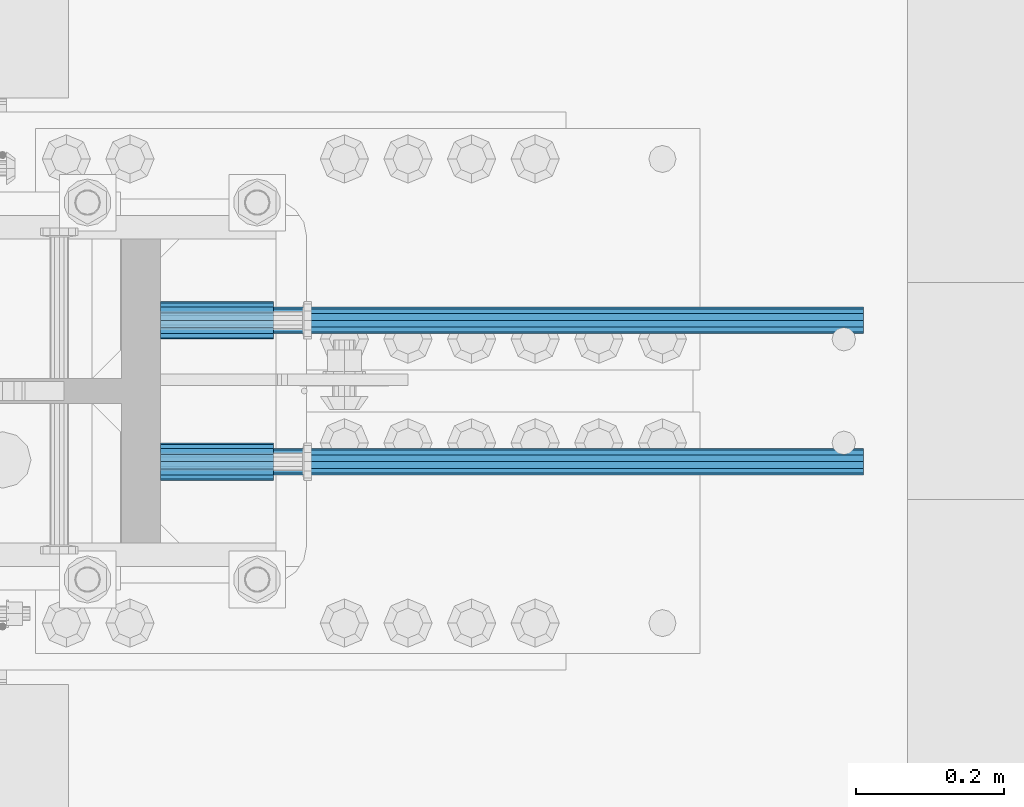
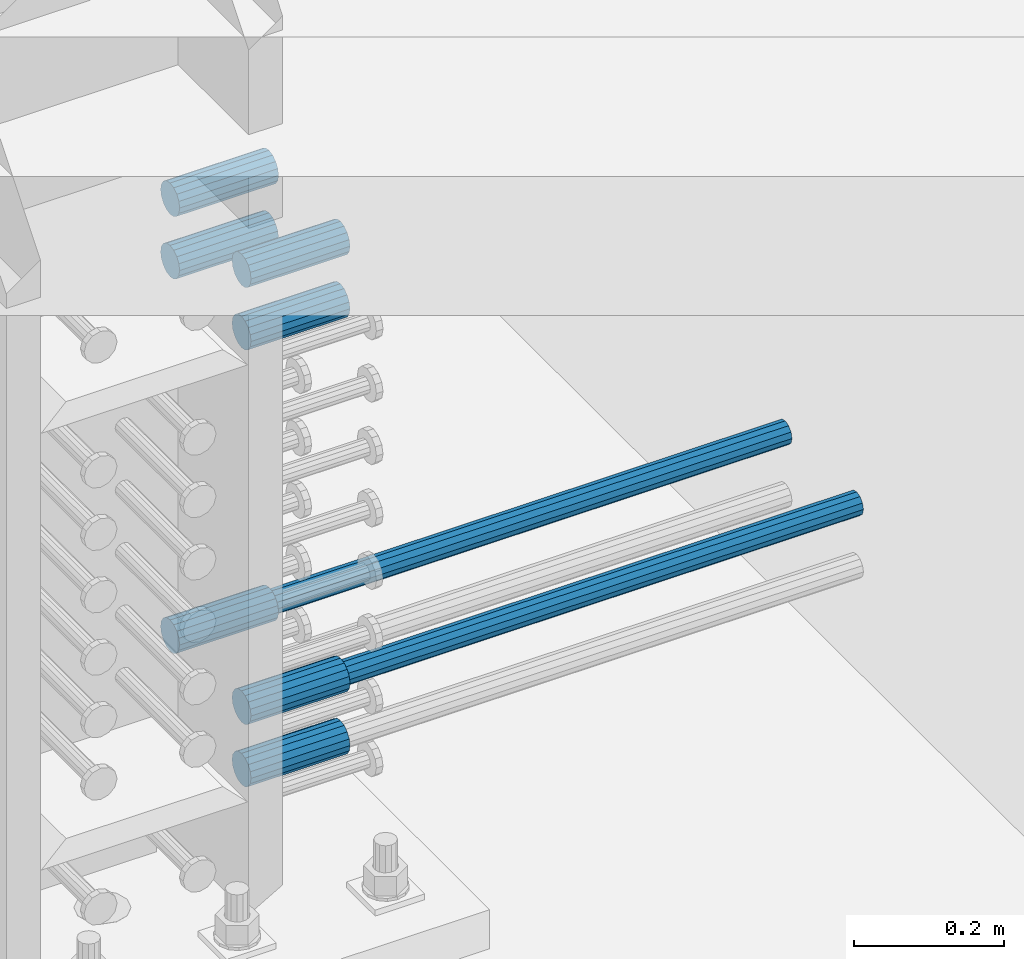
# One storey, part 1232 of 1763: 9 beams, 3 elements without a shape of their own.
"""IFC2X3 building model written with IfcOpenShell, lengths in millimetres."""

import ifcopenshell
import ifcopenshell.guid

model = None  # the IFC model being written
_history = None  # IfcOwnerHistory: only IFC2X3 demands one
_inside = {}  # id of a spatial element -> (the spatial element, [elements in it])
_under = {}  # id of a project, library or spatial element -> (it, [spatial elements below it])
_declared = {}  # id of a project -> (the project, [libraries it declares])
_typed = {}  # id of a type object -> (the type object, [elements of that type])
_made_of = {}  # id of a material, layer set ... -> (it, [elements and type objects made of it])


def new_model(schema):
    """Start an empty IFC model of exactly this schema.

    Asked for "IFC4X3", IfcOpenShell would pick the latest addendum, in which some entities
    have other attributes; the version numbers below select the first issue.
    IFC2X3 requires an IfcOwnerHistory on every rooted entity: one is made here for all.
    """
    global model, _history
    if schema == "IFC4X3":
        model = ifcopenshell.file(schema_version=(4, 3, 0, 0))
    else:
        model = ifcopenshell.file(schema=schema)
    _inside.clear()
    _under.clear()
    _declared.clear()
    _typed.clear()
    _made_of.clear()
    _history = None
    if model.schema == "IFC2X3":
        org = make("IfcOrganization", Name="unknown")
        user = make(
            "IfcPersonAndOrganization",
            ThePerson=make("IfcPerson", FamilyName="unknown"),
            TheOrganization=org,
        )
        app = make(
            "IfcApplication",
            ApplicationDeveloper=org,
            Version="unknown",
            ApplicationFullName="unknown",
            ApplicationIdentifier="unknown",
        )
        _history = make(
            "IfcOwnerHistory",
            OwningUser=user,
            OwningApplication=app,
            ChangeAction="ADDED",
            CreationDate=0,
        )
    return model


def make(cls, **values):
    """One entity of the class cls with the attributes given. An attribute that is None is left unset."""
    return model.create_entity(
        cls, **{name: value for name, value in values.items() if value is not None}
    )


def rooted(cls, **values):
    """An entity with a GlobalId (a new one), such as an element, a storey or a relation."""
    return make(cls, GlobalId=ifcopenshell.guid.new(), OwnerHistory=_history, **values)


def si_unit(unit_type, name, prefix=None):
    """IfcSIUnit, for example si_unit("LENGTHUNIT", "METRE", prefix="MILLI")."""
    return make("IfcSIUnit", UnitType=unit_type, Prefix=prefix, Name=name)


def assignment(units):
    """IfcUnitAssignment: the units of a project."""
    return None if units is None else make("IfcUnitAssignment", Units=units)


def point(xyz):
    """IfcCartesianPoint."""
    return None if xyz is None else make("IfcCartesianPoint", Coordinates=xyz)


def direction(xyz):
    """IfcDirection."""
    return None if xyz is None else make("IfcDirection", DirectionRatios=xyz)


def frame(location, z_axis=None, x_axis=None):
    """IfcAxis2Placement3D, a coordinate frame: its origin and axes. An axis left out is left unset."""
    return make(
        "IfcAxis2Placement3D",
        Location=point(location),
        Axis=direction(z_axis),
        RefDirection=direction(x_axis),
    )


def origin_with_axes():
    """The frame at (0, 0, 0) with the z axis (0, 0, 1) and the x axis (1, 0, 0) written out."""
    return frame((0.0, 0.0, 0.0), z_axis=(0.0, 0.0, 1.0), x_axis=(1.0, 0.0, 0.0))


def place(relative_to, where):
    """IfcLocalPlacement: puts the frame where relative to a parent placement (None: the world)."""
    return make(
        "IfcLocalPlacement", PlacementRelTo=relative_to, RelativePlacement=where
    )


def context(
    kind, dimensions, precision=None, world=None, true_north=None, identifier=None
):
    """IfcGeometricRepresentationContext, for example the 3D "Model" context."""
    return make(
        "IfcGeometricRepresentationContext",
        ContextIdentifier=identifier,
        ContextType=kind,
        CoordinateSpaceDimension=dimensions,
        Precision=precision,
        WorldCoordinateSystem=world,
        TrueNorth=true_north,
    )


def subcontext(parent, identifier, kind, view, scale=None):
    """IfcGeometricRepresentationSubContext, for example "Body" below "Model"."""
    return make(
        "IfcGeometricRepresentationSubContext",
        ContextIdentifier=identifier,
        ContextType=kind,
        ParentContext=parent,
        TargetScale=scale,
        TargetView=view,
    )


def project(units=None, contexts=None):
    """IfcProject with its units and contexts."""
    return rooted(
        "IfcProject",
        Name="project",
        RepresentationContexts=contexts,
        UnitsInContext=assignment(units),
    )


def spatial(cls, under=None, at=None, **own):
    """A site, building, storey or space (cls), placed at a placement, below another one or the project."""
    s = rooted(cls, ObjectPlacement=at, **own)
    if under is not None:
        _under.setdefault(under.id(), (under, []))[1].append(s)
    return s


def faces_of(points, faces, orient=None, outer=None):
    """IfcFace entities. A face is a list of loops; a loop is a list of indices into points, from 0.

    orient and outer hold one flag for each loop. By default every Orientation is true, the
    first loop of a face is its IfcFaceOuterBound and the others are IfcFaceBound.
    """
    made = []
    for i, loops in enumerate(faces):
        bounds = []
        for j, loop in enumerate(loops):
            is_outer = j == 0 if outer is None else outer[i][j]
            bounds.append(
                make(
                    "IfcFaceOuterBound" if is_outer else "IfcFaceBound",
                    Bound=make("IfcPolyLoop", Polygon=[points[k] for k in loop]),
                    Orientation=True if orient is None else orient[i][j],
                )
            )
        made.append(make("IfcFace", Bounds=bounds))
    return made


def faceted_brep(points, faces, orient=None, outer=None, voids=None):
    """IfcFacetedBrep: a solid bounded by flat faces; with voids (closed shells), ...WithVoids."""
    shared = [point(p) for p in points]
    hull = make("IfcClosedShell", CfsFaces=faces_of(shared, faces, orient, outer))
    if voids is None:
        return make("IfcFacetedBrep", Outer=hull)
    return make(
        "IfcFacetedBrepWithVoids",
        Outer=hull,
        Voids=[
            make(cls, CfsFaces=faces_of(shared, fs, o, b)) for cls, fs, o, b in voids
        ],
    )


def shape(context_of_items, identifier, shape_type, items):
    """IfcShapeRepresentation: the items that make up one representation, for example the "Body"."""
    return make(
        "IfcShapeRepresentation",
        ContextOfItems=context_of_items,
        RepresentationIdentifier=identifier,
        RepresentationType=shape_type,
        Items=items,
    )


def material(Name=None, Category=None):
    """IfcMaterial."""
    return make("IfcMaterial", Name=Name, Category=Category)


def made_of(thing, what):
    """Note that an element or type object is made of a material, layer set ...; save() writes the relation."""
    if what is not None:
        _made_of.setdefault(what.id(), (what, []))[1].append(thing)
    return thing


def type_object(cls, material=None, **own):
    """A type object (cls), such as IfcWallType, which elements share."""
    return made_of(rooted(cls, **own), material)


def element(
    cls,
    number,
    at=None,
    inside=None,
    cuts=None,
    type_object=None,
    material=None,
    context=None,
    identifier="Body",
    shape_type=None,
    held_by="IfcProductDefinitionShape",
    body=None,
    shapes=None,
    **own,
):
    """One element of the class cls, such as IfcWall. Its Tag is "e" and its number.

    at: its placement. inside: the storey or other place that contains it. cuts: it is an
    opening in that element (IfcRelVoidsElement). A single representation is given by context,
    identifier, shape_type and body (its items); several are given by shapes. held_by: the class
    of the entity that holds the representations. save() writes the other relations.
    """
    e = rooted(cls, Tag="e%d" % number, ObjectPlacement=at, **own)
    if body is not None:
        shapes = [shape(context, identifier, shape_type, body)]
    if shapes is not None:
        e.Representation = make(held_by, Representations=shapes)
    if inside is not None:
        _inside.setdefault(inside.id(), (inside, []))[1].append(e)
    if cuts is not None:
        rooted(
            "IfcRelVoidsElement", RelatingBuildingElement=cuts, RelatedOpeningElement=e
        )
    if type_object is not None:
        _typed.setdefault(type_object.id(), (type_object, []))[1].append(e)
    return made_of(e, material)


def aggregate(whole, parts):
    """IfcRelAggregates: a whole, such as a stair, and the parts it consists of."""
    return rooted("IfcRelAggregates", RelatingObject=whole, RelatedObjects=parts)


def save(model, path):
    """Write the relations noted so far, then the file.

    IfcRelAggregates (storeys below a building ...), IfcRelContainedInSpatialStructure (elements
    in a storey), IfcRelDefinesByType, IfcRelAssociatesMaterial and IfcRelDeclares: one each for
    every whole, place, type object, material and project.
    """
    for whole, parts in _under.values():
        aggregate(whole, parts)
    for where, things in _inside.values():
        rooted(
            "IfcRelContainedInSpatialStructure",
            RelatedElements=things,
            RelatingStructure=where,
        )
    for kind, things in _typed.values():
        rooted("IfcRelDefinesByType", RelatedObjects=things, RelatingType=kind)
    for what, things in _made_of.values():
        rooted("IfcRelAssociatesMaterial", RelatedObjects=things, RelatingMaterial=what)
    for by, libraries in _declared.values():
        rooted("IfcRelDeclares", RelatingContext=by, RelatedDefinitions=libraries)
    model.write(path)


model = new_model("IFC2X3")

# Units and contexts
model_context = context("Model", 3, precision=1e-05, world=origin_with_axes())
body_context = subcontext(model_context, "Body", "Model", "MODEL_VIEW")
ifc_project = project(units=[si_unit("LENGTHUNIT", "METRE", prefix="MILLI"), si_unit("AREAUNIT", "SQUARE_METRE"), si_unit("VOLUMEUNIT", "CUBIC_METRE"), si_unit("MASSUNIT", "GRAM", prefix="KILO"), si_unit("TIMEUNIT", "SECOND"), si_unit("PLANEANGLEUNIT", "RADIAN"), si_unit("SOLIDANGLEUNIT", "STERADIAN"), si_unit("THERMODYNAMICTEMPERATUREUNIT", "DEGREE_CELSIUS"), si_unit("LUMINOUSINTENSITYUNIT", "LUMEN")], contexts=[model_context])

# Site, building, storey
site_placement = place(None, origin_with_axes())
site = spatial("IfcSite", under=ifc_project, at=site_placement, CompositionType="ELEMENT")
building_placement = place(site_placement, origin_with_axes())
building = spatial("IfcBuilding", under=site, at=building_placement, Name="Undefined", CompositionType="ELEMENT")
storey_placement = place(building_placement, origin_with_axes())
storey = spatial("IfcBuildingStorey", under=building, at=storey_placement, Name="Undefined", CompositionType="ELEMENT", Elevation=0.0)

# Assembly, beams
assembly_1_placement = place(storey_placement, origin_with_axes())
assembly_1 = element("IfcElementAssembly", 1, at=assembly_1_placement, inside=storey, Name="COLUMN", AssemblyPlace="NOTDEFINED", PredefinedType="RIGID_FRAME")
ifc_material = material(Name="STEEL/A706-GR.80")
beam_type_1 = type_object("IfcBeamType", PredefinedType="NOTDEFINED")
beam_1_placement = place(assembly_1_placement, frame((-49189.7122866579, 361.950000000003, 4064.0), z_axis=(0.0, 0.0, 1.0), x_axis=(1.0, 0.0, 0.0)))
beam_1 = element("IfcBeam", 2, at=beam_1_placement, type_object=beam_type_1, material=ifc_material, Name="HALF COUPLER F", context=body_context, shape_type="Brep", body=[
    faceted_brep([(32.7659999999996, -8.95349999999962, -15.507916905568), (32.7659999999996, 0.0, -17.9070000000002), (32.7659999999996, 8.95349999999962, -15.507916905568), (32.7659999999996, 15.507916905568, -8.95350000000008), (32.7659999999996, 17.9069999999992, 0.0), (32.7659999999996, 15.507916905568, 8.95350000000008), (32.7659999999996, 8.95349999999962, 15.507916905568), (32.7659999999996, 0.0, 17.9070000000002), (32.7659999999996, -8.95349999999962, 15.507916905568), (32.7659999999996, -15.507916905568, 8.95350000000008), (32.7659999999996, -17.9069999999992, 0.0), (32.7659999999996, -15.507916905568, -8.95350000000008), (152.400103102711, -15.507916905568, 8.95350000000008), (152.400103102711, -8.95349999999962, 15.507916905568), (152.400103102711, -17.9069999999992, 0.0), (152.400103102711, -15.507916905568, -8.95350000000008), (152.400103102711, -8.95349999999962, -15.507916905568), (152.400103102711, 0.0, -17.9070000000002), (152.400103102711, 8.95349999999962, -15.507916905568), (152.400103102711, 15.507916905568, -8.95350000000008), (152.400103102711, 17.9069999999992, 0.0), (152.400103102711, 15.507916905568, 8.95350000000008), (152.400103102711, 8.95349999999962, 15.507916905568), (152.400103102711, 0.0, 17.9070000000002), (0.0, -23.466540125788, 9.72015918207308), (0.0, -17.9605122421381, 17.9605122421385), (0.0, -9.72015918207398, 23.4665401257867), (0.0, 0.0, 25.4000000000001), (0.0, 9.72015918207398, 23.4665401257867), (0.0, 17.9605122421381, 17.9605122421385), (0.0, 23.466540125788, 9.72015918207308), (0.0, 25.4000000000015, 0.0), (0.0, 23.466540125788, -9.72015918207308), (0.0, 17.9605122421381, -17.9605122421385), (0.0, 9.72015918207398, -23.4665401257867), (0.0, 0.0, -25.4000000000001), (0.0, -9.72015918207398, -23.4665401257867), (0.0, -17.9605122421381, -17.9605122421385), (0.0, -23.466540125788, -9.72015918207308), (0.0, -25.4000000000015, 0.0), (152.400103102711, -25.4000000000015, 0.0), (152.400103102711, -23.466540125788, 9.72015918207308), (152.400103102711, -17.9605122421381, 17.9605122421385), (152.400103102711, -9.72015918207398, 23.4665401257867), (152.400103102711, 0.0, 25.4000000000001), (152.400103102711, 9.72015918207398, 23.4665401257867), (152.400103102711, 17.9605122421381, 17.9605122421385), (152.400103102711, 23.466540125788, 9.72015918207308), (152.400103102711, 25.4000000000015, 0.0), (152.400103102711, 23.466540125788, -9.72015918207308), (152.400103102711, 17.9605122421381, -17.9605122421385), (152.400103102711, 9.72015918207398, -23.4665401257867), (152.400103102711, 0.0, -25.4000000000001), (152.400103102711, -9.72015918207398, -23.4665401257867), (152.400103102711, -17.9605122421381, -17.9605122421385), (152.400103102711, -23.466540125788, -9.72015918207308)], [[[0, 1, 2, 3, 4, 5, 6, 7, 8, 9, 10, 11]], [[12, 9, 8, 13]], [[14, 10, 9, 12]], [[15, 11, 10, 14]], [[16, 0, 11, 15]], [[17, 1, 0, 16]], [[18, 2, 1, 17]], [[19, 3, 2, 18]], [[20, 4, 3, 19]], [[21, 5, 4, 20]], [[22, 6, 5, 21]], [[23, 7, 6, 22]], [[13, 8, 7, 23]], [[24, 25, 26, 27, 28, 29, 30, 31, 32, 33, 34, 35, 36, 37, 38, 39]], [[24, 39, 40, 41]], [[25, 24, 41, 42]], [[26, 25, 42, 43]], [[27, 26, 43, 44]], [[28, 27, 44, 45]], [[29, 28, 45, 46]], [[30, 29, 46, 47]], [[31, 30, 47, 48]], [[32, 31, 48, 49]], [[33, 32, 49, 50]], [[34, 33, 50, 51]], [[35, 34, 51, 52]], [[36, 35, 52, 53]], [[37, 36, 53, 54]], [[38, 37, 54, 55]], [[39, 38, 55, 40]], [[54, 53, 52, 51, 50, 49, 48, 47, 46, 45, 44, 43, 42, 41, 40, 55], [21, 20, 19, 18, 17, 16, 15, 14, 12, 13, 23, 22]]]),
])
beam_2_placement = place(assembly_1_placement, frame((-49189.7122179962, 552.449999999415, 4165.60000000003), z_axis=(0.0, 0.0, 1.0), x_axis=(1.0, 0.0, 0.0)))
beam_2 = element("IfcBeam", 3, at=beam_2_placement, type_object=beam_type_1, material=ifc_material, Name="HALF COUPLER F", context=body_context, shape_type="Brep", body=[
    faceted_brep([(32.7659999999996, -8.95349999999962, -15.507916905568), (32.7659999999996, 0.0, -17.9070000000002), (32.7659999999996, 8.95349999999962, -15.507916905568), (32.7659999999996, 15.507916905568, -8.95350000000008), (32.7659999999996, 17.9069999999992, 0.0), (32.7659999999996, 15.507916905568, 8.95350000000008), (32.7659999999996, 8.95349999999962, 15.507916905568), (32.7659999999996, 0.0, 17.9070000000002), (32.7659999999996, -8.95349999999962, 15.507916905568), (32.7659999999996, -15.507916905568, 8.95350000000008), (32.7659999999996, -17.9069999999992, 0.0), (32.7659999999996, -15.507916905568, -8.95350000000008), (152.400103102711, -15.507916905568, 8.95350000000008), (152.400103102711, -8.95349999999962, 15.507916905568), (152.400103102711, -17.9069999999992, 0.0), (152.400103102711, -15.507916905568, -8.95350000000008), (152.400103102711, -8.95349999999962, -15.507916905568), (152.400103102711, 0.0, -17.9070000000002), (152.400103102711, 8.95349999999962, -15.507916905568), (152.400103102711, 15.507916905568, -8.95350000000008), (152.400103102711, 17.9069999999992, 0.0), (152.400103102711, 15.507916905568, 8.95350000000008), (152.400103102711, 8.95349999999962, 15.507916905568), (152.400103102711, 0.0, 17.9070000000002), (0.0, -23.466540125788, 9.72015918207308), (0.0, -17.9605122421381, 17.9605122421385), (0.0, -9.72015918207398, 23.4665401257867), (0.0, 0.0, 25.4000000000001), (0.0, 9.72015918207398, 23.4665401257867), (0.0, 17.9605122421381, 17.9605122421385), (0.0, 23.466540125788, 9.72015918207308), (0.0, 25.4000000000015, 0.0), (0.0, 23.466540125788, -9.72015918207308), (0.0, 17.9605122421381, -17.9605122421385), (0.0, 9.72015918207398, -23.4665401257867), (0.0, 0.0, -25.4000000000001), (0.0, -9.72015918207398, -23.4665401257867), (0.0, -17.9605122421381, -17.9605122421385), (0.0, -23.466540125788, -9.72015918207308), (0.0, -25.4000000000015, 0.0), (152.400103102711, -25.4000000000015, 0.0), (152.400103102711, -23.466540125788, 9.72015918207308), (152.400103102711, -17.9605122421381, 17.9605122421385), (152.400103102711, -9.72015918207398, 23.4665401257867), (152.400103102711, 0.0, 25.4000000000001), (152.400103102711, 9.72015918207398, 23.4665401257867), (152.400103102711, 17.9605122421381, 17.9605122421385), (152.400103102711, 23.466540125788, 9.72015918207308), (152.400103102711, 25.4000000000015, 0.0), (152.400103102711, 23.466540125788, -9.72015918207308), (152.400103102711, 17.9605122421381, -17.9605122421385), (152.400103102711, 9.72015918207398, -23.4665401257867), (152.400103102711, 0.0, -25.4000000000001), (152.400103102711, -9.72015918207398, -23.4665401257867), (152.400103102711, -17.9605122421381, -17.9605122421385), (152.400103102711, -23.466540125788, -9.72015918207308)], [[[0, 1, 2, 3, 4, 5, 6, 7, 8, 9, 10, 11]], [[12, 9, 8, 13]], [[14, 10, 9, 12]], [[15, 11, 10, 14]], [[16, 0, 11, 15]], [[17, 1, 0, 16]], [[18, 2, 1, 17]], [[19, 3, 2, 18]], [[20, 4, 3, 19]], [[21, 5, 4, 20]], [[22, 6, 5, 21]], [[23, 7, 6, 22]], [[13, 8, 7, 23]], [[24, 25, 26, 27, 28, 29, 30, 31, 32, 33, 34, 35, 36, 37, 38, 39]], [[24, 39, 40, 41]], [[25, 24, 41, 42]], [[26, 25, 42, 43]], [[27, 26, 43, 44]], [[28, 27, 44, 45]], [[29, 28, 45, 46]], [[30, 29, 46, 47]], [[31, 30, 47, 48]], [[32, 31, 48, 49]], [[33, 32, 49, 50]], [[34, 33, 50, 51]], [[35, 34, 51, 52]], [[36, 35, 52, 53]], [[37, 36, 53, 54]], [[38, 37, 54, 55]], [[39, 38, 55, 40]], [[54, 53, 52, 51, 50, 49, 48, 47, 46, 45, 44, 43, 42, 41, 40, 55], [21, 20, 19, 18, 17, 16, 15, 14, 12, 13, 23, 22]]]),
])
beam_3_placement = place(assembly_1_placement, frame((-49189.712286658, 361.950000000003, 4165.60000000003), z_axis=(0.0, 0.0, 1.0), x_axis=(1.0, 0.0, 0.0)))
beam_3 = element("IfcBeam", 4, at=beam_3_placement, type_object=beam_type_1, material=ifc_material, Name="HALF COUPLER F", context=body_context, shape_type="Brep", body=[
    faceted_brep([(32.7659999999996, -8.95349999999962, -15.507916905568), (32.7659999999996, 0.0, -17.9070000000002), (32.7659999999996, 8.95349999999962, -15.507916905568), (32.7659999999996, 15.507916905568, -8.95350000000008), (32.7659999999996, 17.9069999999992, 0.0), (32.7659999999996, 15.507916905568, 8.95350000000008), (32.7659999999996, 8.95349999999962, 15.507916905568), (32.7659999999996, 0.0, 17.9070000000002), (32.7659999999996, -8.95349999999962, 15.507916905568), (32.7659999999996, -15.507916905568, 8.95350000000008), (32.7659999999996, -17.9069999999992, 0.0), (32.7659999999996, -15.507916905568, -8.95350000000008), (152.400103102711, -15.507916905568, 8.95350000000008), (152.400103102711, -8.95349999999962, 15.507916905568), (152.400103102711, -17.9069999999992, 0.0), (152.400103102711, -15.507916905568, -8.95350000000008), (152.400103102711, -8.95349999999962, -15.507916905568), (152.400103102711, 0.0, -17.9070000000002), (152.400103102711, 8.95349999999962, -15.507916905568), (152.400103102711, 15.507916905568, -8.95350000000008), (152.400103102711, 17.9069999999992, 0.0), (152.400103102711, 15.507916905568, 8.95350000000008), (152.400103102711, 8.95349999999962, 15.507916905568), (152.400103102711, 0.0, 17.9070000000002), (0.0, -23.466540125788, 9.72015918207308), (0.0, -17.9605122421381, 17.9605122421385), (0.0, -9.72015918207398, 23.4665401257867), (0.0, 0.0, 25.4000000000001), (0.0, 9.72015918207398, 23.4665401257867), (0.0, 17.9605122421381, 17.9605122421385), (0.0, 23.466540125788, 9.72015918207308), (0.0, 25.4000000000015, 0.0), (0.0, 23.466540125788, -9.72015918207308), (0.0, 17.9605122421381, -17.9605122421385), (0.0, 9.72015918207398, -23.4665401257867), (0.0, 0.0, -25.4000000000001), (0.0, -9.72015918207398, -23.4665401257867), (0.0, -17.9605122421381, -17.9605122421385), (0.0, -23.466540125788, -9.72015918207308), (0.0, -25.4000000000015, 0.0), (152.400103102711, -25.4000000000015, 0.0), (152.400103102711, -23.466540125788, 9.72015918207308), (152.400103102711, -17.9605122421381, 17.9605122421385), (152.400103102711, -9.72015918207398, 23.4665401257867), (152.400103102711, 0.0, 25.4000000000001), (152.400103102711, 9.72015918207398, 23.4665401257867), (152.400103102711, 17.9605122421381, 17.9605122421385), (152.400103102711, 23.466540125788, 9.72015918207308), (152.400103102711, 25.4000000000015, 0.0), (152.400103102711, 23.466540125788, -9.72015918207308), (152.400103102711, 17.9605122421381, -17.9605122421385), (152.400103102711, 9.72015918207398, -23.4665401257867), (152.400103102711, 0.0, -25.4000000000001), (152.400103102711, -9.72015918207398, -23.4665401257867), (152.400103102711, -17.9605122421381, -17.9605122421385), (152.400103102711, -23.466540125788, -9.72015918207308)], [[[0, 1, 2, 3, 4, 5, 6, 7, 8, 9, 10, 11]], [[12, 9, 8, 13]], [[14, 10, 9, 12]], [[15, 11, 10, 14]], [[16, 0, 11, 15]], [[17, 1, 0, 16]], [[18, 2, 1, 17]], [[19, 3, 2, 18]], [[20, 4, 3, 19]], [[21, 5, 4, 20]], [[22, 6, 5, 21]], [[23, 7, 6, 22]], [[13, 8, 7, 23]], [[24, 25, 26, 27, 28, 29, 30, 31, 32, 33, 34, 35, 36, 37, 38, 39]], [[24, 39, 40, 41]], [[25, 24, 41, 42]], [[26, 25, 42, 43]], [[27, 26, 43, 44]], [[28, 27, 44, 45]], [[29, 28, 45, 46]], [[30, 29, 46, 47]], [[31, 30, 47, 48]], [[32, 31, 48, 49]], [[33, 32, 49, 50]], [[34, 33, 50, 51]], [[35, 34, 51, 52]], [[36, 35, 52, 53]], [[37, 36, 53, 54]], [[38, 37, 54, 55]], [[39, 38, 55, 40]], [[54, 53, 52, 51, 50, 49, 48, 47, 46, 45, 44, 43, 42, 41, 40, 55], [21, 20, 19, 18, 17, 16, 15, 14, 12, 13, 23, 22]]]),
])
beam_4_placement = place(assembly_1_placement, frame((-49189.7122867317, 552.449999999415, 4775.20000000009), z_axis=(0.0, 0.0, 1.0), x_axis=(1.0, 0.0, 0.0)))
beam_4 = element("IfcBeam", 5, at=beam_4_placement, type_object=beam_type_1, material=ifc_material, Name="HALF COUPLER F", context=body_context, shape_type="Brep", body=[
    faceted_brep([(32.7659999999996, -8.95349999999962, -15.507916905568), (32.7659999999996, 0.0, -17.9070000000002), (32.7659999999996, 8.95349999999962, -15.507916905568), (32.7659999999996, 15.507916905568, -8.95350000000008), (32.7659999999996, 17.9069999999992, 0.0), (32.7659999999996, 15.507916905568, 8.95350000000008), (32.7659999999996, 8.95349999999962, 15.507916905568), (32.7659999999996, 0.0, 17.9070000000002), (32.7659999999996, -8.95349999999962, 15.507916905568), (32.7659999999996, -15.507916905568, 8.95350000000008), (32.7659999999996, -17.9069999999992, 0.0), (32.7659999999996, -15.507916905568, -8.95350000000008), (152.400103102711, -15.507916905568, 8.95350000000008), (152.400103102711, -8.95349999999962, 15.507916905568), (152.400103102711, -17.9069999999992, 0.0), (152.400103102711, -15.507916905568, -8.95350000000008), (152.400103102711, -8.95349999999962, -15.507916905568), (152.400103102711, 0.0, -17.9070000000002), (152.400103102711, 8.95349999999962, -15.507916905568), (152.400103102711, 15.507916905568, -8.95350000000008), (152.400103102711, 17.9069999999992, 0.0), (152.400103102711, 15.507916905568, 8.95350000000008), (152.400103102711, 8.95349999999962, 15.507916905568), (152.400103102711, 0.0, 17.9070000000002), (0.0, -23.466540125788, 9.72015918207308), (0.0, -17.9605122421381, 17.9605122421385), (0.0, -9.72015918207398, 23.4665401257867), (0.0, 0.0, 25.4000000000001), (0.0, 9.72015918207398, 23.4665401257867), (0.0, 17.9605122421381, 17.9605122421385), (0.0, 23.466540125788, 9.72015918207308), (0.0, 25.4000000000015, 0.0), (0.0, 23.466540125788, -9.72015918207308), (0.0, 17.9605122421381, -17.9605122421385), (0.0, 9.72015918207398, -23.4665401257867), (0.0, 0.0, -25.4000000000001), (0.0, -9.72015918207398, -23.4665401257867), (0.0, -17.9605122421381, -17.9605122421385), (0.0, -23.466540125788, -9.72015918207308), (0.0, -25.4000000000015, 0.0), (152.400103102711, -25.4000000000015, 0.0), (152.400103102711, -23.466540125788, 9.72015918207308), (152.400103102711, -17.9605122421381, 17.9605122421385), (152.400103102711, -9.72015918207398, 23.4665401257867), (152.400103102711, 0.0, 25.4000000000001), (152.400103102711, 9.72015918207398, 23.4665401257867), (152.400103102711, 17.9605122421381, 17.9605122421385), (152.400103102711, 23.466540125788, 9.72015918207308), (152.400103102711, 25.4000000000015, 0.0), (152.400103102711, 23.466540125788, -9.72015918207308), (152.400103102711, 17.9605122421381, -17.9605122421385), (152.400103102711, 9.72015918207398, -23.4665401257867), (152.400103102711, 0.0, -25.4000000000001), (152.400103102711, -9.72015918207398, -23.4665401257867), (152.400103102711, -17.9605122421381, -17.9605122421385), (152.400103102711, -23.466540125788, -9.72015918207308)], [[[0, 1, 2, 3, 4, 5, 6, 7, 8, 9, 10, 11]], [[12, 9, 8, 13]], [[14, 10, 9, 12]], [[15, 11, 10, 14]], [[16, 0, 11, 15]], [[17, 1, 0, 16]], [[18, 2, 1, 17]], [[19, 3, 2, 18]], [[20, 4, 3, 19]], [[21, 5, 4, 20]], [[22, 6, 5, 21]], [[23, 7, 6, 22]], [[13, 8, 7, 23]], [[24, 25, 26, 27, 28, 29, 30, 31, 32, 33, 34, 35, 36, 37, 38, 39]], [[24, 39, 40, 41]], [[25, 24, 41, 42]], [[26, 25, 42, 43]], [[27, 26, 43, 44]], [[28, 27, 44, 45]], [[29, 28, 45, 46]], [[30, 29, 46, 47]], [[31, 30, 47, 48]], [[32, 31, 48, 49]], [[33, 32, 49, 50]], [[34, 33, 50, 51]], [[35, 34, 51, 52]], [[36, 35, 52, 53]], [[37, 36, 53, 54]], [[38, 37, 54, 55]], [[39, 38, 55, 40]], [[54, 53, 52, 51, 50, 49, 48, 47, 46, 45, 44, 43, 42, 41, 40, 55], [21, 20, 19, 18, 17, 16, 15, 14, 12, 13, 23, 22]]]),
])
beam_5_placement = place(assembly_1_placement, frame((-49189.7123553935, 361.950000000003, 4775.20000000009), z_axis=(0.0, 0.0, 1.0), x_axis=(1.0, 0.0, 0.0)))
beam_5 = element("IfcBeam", 6, at=beam_5_placement, type_object=beam_type_1, material=ifc_material, Name="HALF COUPLER F", context=body_context, shape_type="Brep", body=[
    faceted_brep([(32.7659999999996, -8.95349999999962, -15.507916905568), (32.7659999999996, 0.0, -17.9070000000002), (32.7659999999996, 8.95349999999962, -15.507916905568), (32.7659999999996, 15.507916905568, -8.95350000000008), (32.7659999999996, 17.9069999999992, 0.0), (32.7659999999996, 15.507916905568, 8.95350000000008), (32.7659999999996, 8.95349999999962, 15.507916905568), (32.7659999999996, 0.0, 17.9070000000002), (32.7659999999996, -8.95349999999962, 15.507916905568), (32.7659999999996, -15.507916905568, 8.95350000000008), (32.7659999999996, -17.9069999999992, 0.0), (32.7659999999996, -15.507916905568, -8.95350000000008), (152.400103102711, -15.507916905568, 8.95350000000008), (152.400103102711, -8.95349999999962, 15.507916905568), (152.400103102711, -17.9069999999992, 0.0), (152.400103102711, -15.507916905568, -8.95350000000008), (152.400103102711, -8.95349999999962, -15.507916905568), (152.400103102711, 0.0, -17.9070000000002), (152.400103102711, 8.95349999999962, -15.507916905568), (152.400103102711, 15.507916905568, -8.95350000000008), (152.400103102711, 17.9069999999992, 0.0), (152.400103102711, 15.507916905568, 8.95350000000008), (152.400103102711, 8.95349999999962, 15.507916905568), (152.400103102711, 0.0, 17.9070000000002), (0.0, -23.466540125788, 9.72015918207308), (0.0, -17.9605122421381, 17.9605122421385), (0.0, -9.72015918207398, 23.4665401257867), (0.0, 0.0, 25.4000000000001), (0.0, 9.72015918207398, 23.4665401257867), (0.0, 17.9605122421381, 17.9605122421385), (0.0, 23.466540125788, 9.72015918207308), (0.0, 25.4000000000015, 0.0), (0.0, 23.466540125788, -9.72015918207308), (0.0, 17.9605122421381, -17.9605122421385), (0.0, 9.72015918207398, -23.4665401257867), (0.0, 0.0, -25.4000000000001), (0.0, -9.72015918207398, -23.4665401257867), (0.0, -17.9605122421381, -17.9605122421385), (0.0, -23.466540125788, -9.72015918207308), (0.0, -25.4000000000015, 0.0), (152.400103102711, -25.4000000000015, 0.0), (152.400103102711, -23.466540125788, 9.72015918207308), (152.400103102711, -17.9605122421381, 17.9605122421385), (152.400103102711, -9.72015918207398, 23.4665401257867), (152.400103102711, 0.0, 25.4000000000001), (152.400103102711, 9.72015918207398, 23.4665401257867), (152.400103102711, 17.9605122421381, 17.9605122421385), (152.400103102711, 23.466540125788, 9.72015918207308), (152.400103102711, 25.4000000000015, 0.0), (152.400103102711, 23.466540125788, -9.72015918207308), (152.400103102711, 17.9605122421381, -17.9605122421385), (152.400103102711, 9.72015918207398, -23.4665401257867), (152.400103102711, 0.0, -25.4000000000001), (152.400103102711, -9.72015918207398, -23.4665401257867), (152.400103102711, -17.9605122421381, -17.9605122421385), (152.400103102711, -23.466540125788, -9.72015918207308)], [[[0, 1, 2, 3, 4, 5, 6, 7, 8, 9, 10, 11]], [[12, 9, 8, 13]], [[14, 10, 9, 12]], [[15, 11, 10, 14]], [[16, 0, 11, 15]], [[17, 1, 0, 16]], [[18, 2, 1, 17]], [[19, 3, 2, 18]], [[20, 4, 3, 19]], [[21, 5, 4, 20]], [[22, 6, 5, 21]], [[23, 7, 6, 22]], [[13, 8, 7, 23]], [[24, 25, 26, 27, 28, 29, 30, 31, 32, 33, 34, 35, 36, 37, 38, 39]], [[24, 39, 40, 41]], [[25, 24, 41, 42]], [[26, 25, 42, 43]], [[27, 26, 43, 44]], [[28, 27, 44, 45]], [[29, 28, 45, 46]], [[30, 29, 46, 47]], [[31, 30, 47, 48]], [[32, 31, 48, 49]], [[33, 32, 49, 50]], [[34, 33, 50, 51]], [[35, 34, 51, 52]], [[36, 35, 52, 53]], [[37, 36, 53, 54]], [[38, 37, 54, 55]], [[39, 38, 55, 40]], [[54, 53, 52, 51, 50, 49, 48, 47, 46, 45, 44, 43, 42, 41, 40, 55], [21, 20, 19, 18, 17, 16, 15, 14, 12, 13, 23, 22]]]),
])
beam_6_placement = place(assembly_1_placement, frame((-49189.7122867317, 552.449999999415, 4876.80000000009), z_axis=(0.0, 0.0, 1.0), x_axis=(1.0, 0.0, 0.0)))
beam_6 = element("IfcBeam", 7, at=beam_6_placement, type_object=beam_type_1, material=ifc_material, Name="HALF COUPLER F", context=body_context, shape_type="Brep", body=[
    faceted_brep([(32.7659999999996, -8.95349999999962, -15.507916905568), (32.7659999999996, 0.0, -17.9070000000002), (32.7659999999996, 8.95349999999962, -15.507916905568), (32.7659999999996, 15.507916905568, -8.95350000000008), (32.7659999999996, 17.9069999999992, 0.0), (32.7659999999996, 15.507916905568, 8.95350000000008), (32.7659999999996, 8.95349999999962, 15.507916905568), (32.7659999999996, 0.0, 17.9070000000002), (32.7659999999996, -8.95349999999962, 15.507916905568), (32.7659999999996, -15.507916905568, 8.95350000000008), (32.7659999999996, -17.9069999999992, 0.0), (32.7659999999996, -15.507916905568, -8.95350000000008), (152.400103102711, -15.507916905568, 8.95350000000008), (152.400103102711, -8.95349999999962, 15.507916905568), (152.400103102711, -17.9069999999992, 0.0), (152.400103102711, -15.507916905568, -8.95350000000008), (152.400103102711, -8.95349999999962, -15.507916905568), (152.400103102711, 0.0, -17.9070000000002), (152.400103102711, 8.95349999999962, -15.507916905568), (152.400103102711, 15.507916905568, -8.95350000000008), (152.400103102711, 17.9069999999992, 0.0), (152.400103102711, 15.507916905568, 8.95350000000008), (152.400103102711, 8.95349999999962, 15.507916905568), (152.400103102711, 0.0, 17.9070000000002), (0.0, -23.466540125788, 9.72015918207308), (0.0, -17.9605122421381, 17.9605122421385), (0.0, -9.72015918207398, 23.4665401257867), (0.0, 0.0, 25.4000000000001), (0.0, 9.72015918207398, 23.4665401257867), (0.0, 17.9605122421381, 17.9605122421385), (0.0, 23.466540125788, 9.72015918207308), (0.0, 25.4000000000015, 0.0), (0.0, 23.466540125788, -9.72015918207308), (0.0, 17.9605122421381, -17.9605122421385), (0.0, 9.72015918207398, -23.4665401257867), (0.0, 0.0, -25.4000000000001), (0.0, -9.72015918207398, -23.4665401257867), (0.0, -17.9605122421381, -17.9605122421385), (0.0, -23.466540125788, -9.72015918207308), (0.0, -25.4000000000015, 0.0), (152.400103102711, -25.4000000000015, 0.0), (152.400103102711, -23.466540125788, 9.72015918207308), (152.400103102711, -17.9605122421381, 17.9605122421385), (152.400103102711, -9.72015918207398, 23.4665401257867), (152.400103102711, 0.0, 25.4000000000001), (152.400103102711, 9.72015918207398, 23.4665401257867), (152.400103102711, 17.9605122421381, 17.9605122421385), (152.400103102711, 23.466540125788, 9.72015918207308), (152.400103102711, 25.4000000000015, 0.0), (152.400103102711, 23.466540125788, -9.72015918207308), (152.400103102711, 17.9605122421381, -17.9605122421385), (152.400103102711, 9.72015918207398, -23.4665401257867), (152.400103102711, 0.0, -25.4000000000001), (152.400103102711, -9.72015918207398, -23.4665401257867), (152.400103102711, -17.9605122421381, -17.9605122421385), (152.400103102711, -23.466540125788, -9.72015918207308)], [[[0, 1, 2, 3, 4, 5, 6, 7, 8, 9, 10, 11]], [[12, 9, 8, 13]], [[14, 10, 9, 12]], [[15, 11, 10, 14]], [[16, 0, 11, 15]], [[17, 1, 0, 16]], [[18, 2, 1, 17]], [[19, 3, 2, 18]], [[20, 4, 3, 19]], [[21, 5, 4, 20]], [[22, 6, 5, 21]], [[23, 7, 6, 22]], [[13, 8, 7, 23]], [[24, 25, 26, 27, 28, 29, 30, 31, 32, 33, 34, 35, 36, 37, 38, 39]], [[24, 39, 40, 41]], [[25, 24, 41, 42]], [[26, 25, 42, 43]], [[27, 26, 43, 44]], [[28, 27, 44, 45]], [[29, 28, 45, 46]], [[30, 29, 46, 47]], [[31, 30, 47, 48]], [[32, 31, 48, 49]], [[33, 32, 49, 50]], [[34, 33, 50, 51]], [[35, 34, 51, 52]], [[36, 35, 52, 53]], [[37, 36, 53, 54]], [[38, 37, 54, 55]], [[39, 38, 55, 40]], [[54, 53, 52, 51, 50, 49, 48, 47, 46, 45, 44, 43, 42, 41, 40, 55], [21, 20, 19, 18, 17, 16, 15, 14, 12, 13, 23, 22]]]),
])
beam_7_placement = place(assembly_1_placement, frame((-49189.7123553935, 361.950000000003, 4876.80000000009), z_axis=(0.0, 0.0, 1.0), x_axis=(1.0, 0.0, 0.0)))
beam_7 = element("IfcBeam", 8, at=beam_7_placement, type_object=beam_type_1, material=ifc_material, Name="HALF COUPLER F", context=body_context, shape_type="Brep", body=[
    faceted_brep([(32.7659999999996, -8.95349999999962, -15.507916905568), (32.7659999999996, 0.0, -17.9070000000002), (32.7659999999996, 8.95349999999962, -15.507916905568), (32.7659999999996, 15.507916905568, -8.95350000000008), (32.7659999999996, 17.9069999999992, 0.0), (32.7659999999996, 15.507916905568, 8.95350000000008), (32.7659999999996, 8.95349999999962, 15.507916905568), (32.7659999999996, 0.0, 17.9070000000002), (32.7659999999996, -8.95349999999962, 15.507916905568), (32.7659999999996, -15.507916905568, 8.95350000000008), (32.7659999999996, -17.9069999999992, 0.0), (32.7659999999996, -15.507916905568, -8.95350000000008), (152.400103102711, -15.507916905568, 8.95350000000008), (152.400103102711, -8.95349999999962, 15.507916905568), (152.400103102711, -17.9069999999992, 0.0), (152.400103102711, -15.507916905568, -8.95350000000008), (152.400103102711, -8.95349999999962, -15.507916905568), (152.400103102711, 0.0, -17.9070000000002), (152.400103102711, 8.95349999999962, -15.507916905568), (152.400103102711, 15.507916905568, -8.95350000000008), (152.400103102711, 17.9069999999992, 0.0), (152.400103102711, 15.507916905568, 8.95350000000008), (152.400103102711, 8.95349999999962, 15.507916905568), (152.400103102711, 0.0, 17.9070000000002), (0.0, -23.466540125788, 9.72015918207308), (0.0, -17.9605122421381, 17.9605122421385), (0.0, -9.72015918207398, 23.4665401257867), (0.0, 0.0, 25.4000000000001), (0.0, 9.72015918207398, 23.4665401257867), (0.0, 17.9605122421381, 17.9605122421385), (0.0, 23.466540125788, 9.72015918207308), (0.0, 25.4000000000015, 0.0), (0.0, 23.466540125788, -9.72015918207308), (0.0, 17.9605122421381, -17.9605122421385), (0.0, 9.72015918207398, -23.4665401257867), (0.0, 0.0, -25.4000000000001), (0.0, -9.72015918207398, -23.4665401257867), (0.0, -17.9605122421381, -17.9605122421385), (0.0, -23.466540125788, -9.72015918207308), (0.0, -25.4000000000015, 0.0), (152.400103102711, -25.4000000000015, 0.0), (152.400103102711, -23.466540125788, 9.72015918207308), (152.400103102711, -17.9605122421381, 17.9605122421385), (152.400103102711, -9.72015918207398, 23.4665401257867), (152.400103102711, 0.0, 25.4000000000001), (152.400103102711, 9.72015918207398, 23.4665401257867), (152.400103102711, 17.9605122421381, 17.9605122421385), (152.400103102711, 23.466540125788, 9.72015918207308), (152.400103102711, 25.4000000000015, 0.0), (152.400103102711, 23.466540125788, -9.72015918207308), (152.400103102711, 17.9605122421381, -17.9605122421385), (152.400103102711, 9.72015918207398, -23.4665401257867), (152.400103102711, 0.0, -25.4000000000001), (152.400103102711, -9.72015918207398, -23.4665401257867), (152.400103102711, -17.9605122421381, -17.9605122421385), (152.400103102711, -23.466540125788, -9.72015918207308)], [[[0, 1, 2, 3, 4, 5, 6, 7, 8, 9, 10, 11]], [[12, 9, 8, 13]], [[14, 10, 9, 12]], [[15, 11, 10, 14]], [[16, 0, 11, 15]], [[17, 1, 0, 16]], [[18, 2, 1, 17]], [[19, 3, 2, 18]], [[20, 4, 3, 19]], [[21, 5, 4, 20]], [[22, 6, 5, 21]], [[23, 7, 6, 22]], [[13, 8, 7, 23]], [[24, 25, 26, 27, 28, 29, 30, 31, 32, 33, 34, 35, 36, 37, 38, 39]], [[24, 39, 40, 41]], [[25, 24, 41, 42]], [[26, 25, 42, 43]], [[27, 26, 43, 44]], [[28, 27, 44, 45]], [[29, 28, 45, 46]], [[30, 29, 46, 47]], [[31, 30, 47, 48]], [[32, 31, 48, 49]], [[33, 32, 49, 50]], [[34, 33, 50, 51]], [[35, 34, 51, 52]], [[36, 35, 52, 53]], [[37, 36, 53, 54]], [[38, 37, 54, 55]], [[39, 38, 55, 40]], [[54, 53, 52, 51, 50, 49, 48, 47, 46, 45, 44, 43, 42, 41, 40, 55], [21, 20, 19, 18, 17, 16, 15, 14, 12, 13, 23, 22]]]),
])
aggregate(assembly_1, [beam_1, beam_2, beam_3, beam_4, beam_5, beam_6, beam_7])

# Assembly, beam
assembly_2_placement = place(storey_placement, origin_with_axes())
assembly_2 = element("IfcElementAssembly", 9, at=assembly_2_placement, inside=storey, Name="REBAR", AssemblyPlace="NOTDEFINED", PredefinedType="RIGID_FRAME")
beam_type_2 = type_object("IfcBeamType", Name="#11 REBAR", PredefinedType="NOTDEFINED")
beam_8_placement = place(assembly_2_placement, frame((-49156.9463553198, 361.949999998902, 4165.60000000003), z_axis=(0.0, 0.0, 1.0), x_axis=(1.0, 0.0, 0.0)))
beam_8 = element("IfcBeam", 10, at=beam_8_placement, type_object=beam_type_2, material=ifc_material, Name="REBAR", ObjectType="#11 REBAR", context=body_context, shape_type="Brep", body=[
    faceted_brep([(0.0, -17.9069999999992, 0.0), (0.0, -15.507916905568, -8.95349999999962), (914.400000001086, -15.507916905568, -8.95349999999962), (914.400000001086, -17.9069999999992, 0.0), (0.0, -8.95349999999962, -15.507916905568), (914.400000001086, -8.95349999999962, -15.507916905568), (0.0, 0.0, -17.9070000000002), (914.400000001086, 0.0, -17.9070000000002), (0.0, 8.95349999999962, -15.507916905568), (914.400000001086, 8.95349999999962, -15.507916905568), (0.0, 15.507916905568, -8.95349999999962), (914.400000001086, 15.507916905568, -8.95349999999962), (0.0, 17.9069999999992, 0.0), (914.400000001086, 17.9069999999992, 0.0), (0.0, 15.507916905568, 8.95349999999962), (914.400000001086, 15.507916905568, 8.95349999999962), (0.0, 8.95349999999962, 15.507916905568), (914.400000001086, 8.95349999999962, 15.507916905568), (0.0, 0.0, 17.9070000000002), (914.400000001086, 0.0, 17.9070000000002), (0.0, -8.95349999999962, 15.507916905568), (914.400000001086, -8.95349999999962, 15.507916905568), (0.0, -15.507916905568, 8.95349999999962), (914.400000001086, -15.507916905568, 8.95349999999962)], [[[0, 1, 2, 3]], [[1, 4, 5, 2]], [[4, 6, 7, 5]], [[6, 8, 9, 7]], [[8, 10, 11, 9]], [[10, 12, 13, 11]], [[12, 14, 15, 13]], [[14, 16, 17, 15]], [[16, 18, 19, 17]], [[18, 20, 21, 19]], [[20, 22, 23, 21]], [[22, 0, 3, 23]], [[5, 7, 9, 11, 13, 15, 17, 19, 21, 23, 3, 2]], [[22, 20, 18, 16, 14, 12, 10, 8, 6, 4, 1, 0]]]),
])
aggregate(assembly_2, [beam_8])

assembly_3_placement = place(storey_placement, origin_with_axes())
assembly_3 = element("IfcElementAssembly", 11, at=assembly_3_placement, inside=storey, Name="REBAR", AssemblyPlace="NOTDEFINED", PredefinedType="RIGID_FRAME")
beam_9_placement = place(assembly_3_placement, frame((-49156.9462866573, 552.449999998316, 4165.60000000003), z_axis=(0.0, 0.0, 1.0), x_axis=(1.0, 0.0, 0.0)))
beam_9 = element("IfcBeam", 12, at=beam_9_placement, type_object=beam_type_2, material=ifc_material, Name="REBAR", ObjectType="#11 REBAR", context=body_context, shape_type="Brep", body=[
    faceted_brep([(0.0, -17.9069999999992, 0.0), (0.0, -15.507916905568, -8.95349999999962), (914.400000001086, -15.507916905568, -8.95349999999962), (914.400000001086, -17.9069999999992, 0.0), (0.0, -8.95349999999962, -15.507916905568), (914.400000001086, -8.95349999999962, -15.507916905568), (0.0, 0.0, -17.9070000000002), (914.400000001086, 0.0, -17.9070000000002), (0.0, 8.95349999999962, -15.507916905568), (914.400000001086, 8.95349999999962, -15.507916905568), (0.0, 15.507916905568, -8.95349999999962), (914.400000001086, 15.507916905568, -8.95349999999962), (0.0, 17.9069999999992, 0.0), (914.400000001086, 17.9069999999992, 0.0), (0.0, 15.507916905568, 8.95349999999962), (914.400000001086, 15.507916905568, 8.95349999999962), (0.0, 8.95349999999962, 15.507916905568), (914.400000001086, 8.95349999999962, 15.507916905568), (0.0, 0.0, 17.9070000000002), (914.400000001086, 0.0, 17.9070000000002), (0.0, -8.95349999999962, 15.507916905568), (914.400000001086, -8.95349999999962, 15.507916905568), (0.0, -15.507916905568, 8.95349999999962), (914.400000001086, -15.507916905568, 8.95349999999962)], [[[0, 1, 2, 3]], [[1, 4, 5, 2]], [[4, 6, 7, 5]], [[6, 8, 9, 7]], [[8, 10, 11, 9]], [[10, 12, 13, 11]], [[12, 14, 15, 13]], [[14, 16, 17, 15]], [[16, 18, 19, 17]], [[18, 20, 21, 19]], [[20, 22, 23, 21]], [[22, 0, 3, 23]], [[5, 7, 9, 11, 13, 15, 17, 19, 21, 23, 3, 2]], [[22, 20, 18, 16, 14, 12, 10, 8, 6, 4, 1, 0]]]),
])
aggregate(assembly_3, [beam_9])

save(model, "model.ifc")
